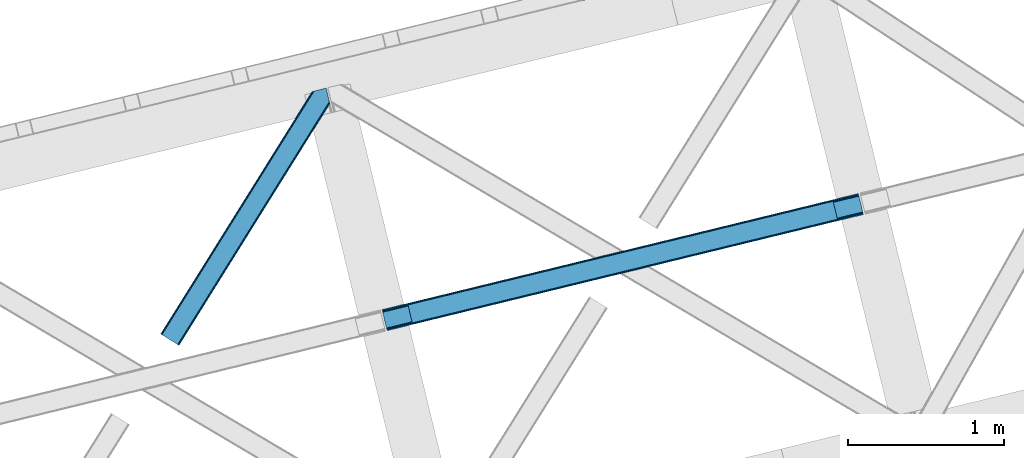
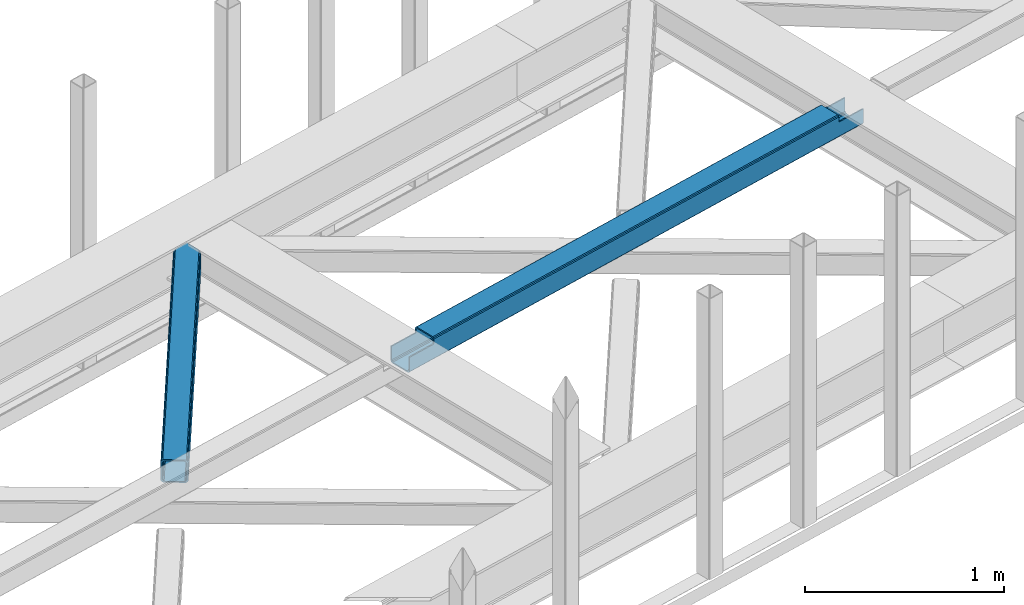
# One storey, part 51 of 67: 1 beam, 1 member.
"""IFC4 building model written with IfcOpenShell, lengths in millimetres."""

from ifc_helpers import new_model, entity, si_unit, converted_unit, derived_unit, direction, frame, origin, place, context, subcontext, project, spatial, triangles, polygons, material, type_object, element, save


model = new_model("IFC4")

# Units and contexts
model_context = context("Model", 3, precision=0.01, world=origin(), true_north=direction((6.12303176911189e-17, 1.0)))
plan_context = context("Plan", 3, precision=0.01, world=origin(), true_north=direction((6.12303176911189e-17, 1.0)))
body_context = subcontext(model_context, "Body", "Model", "MODEL_VIEW")
ifc_project = project(units=[si_unit("LENGTHUNIT", "METRE", prefix="MILLI"), si_unit("AREAUNIT", "SQUARE_METRE"), si_unit("VOLUMEUNIT", "CUBIC_METRE"), converted_unit("PLANEANGLEUNIT", "DEGREE", entity("IfcRatioMeasure", 0.0174532925199433), si_unit("PLANEANGLEUNIT", "RADIAN"), dimensions=[0, 0, 0, 0, 0, 0, 0]), si_unit("MASSUNIT", "GRAM", prefix="KILO"), derived_unit("MASSDENSITYUNIT", [(si_unit("MASSUNIT", "GRAM", prefix="KILO"), 1), (si_unit("LENGTHUNIT", "METRE"), -3)]), derived_unit("MOMENTOFINERTIAUNIT", [(si_unit("LENGTHUNIT", "METRE"), 4)]), si_unit("TIMEUNIT", "SECOND"), si_unit("FREQUENCYUNIT", "HERTZ"), si_unit("THERMODYNAMICTEMPERATUREUNIT", "DEGREE_CELSIUS"), derived_unit("THERMALTRANSMITTANCEUNIT", [(si_unit("MASSUNIT", "GRAM", prefix="KILO"), 1), (si_unit("THERMODYNAMICTEMPERATUREUNIT", "KELVIN"), -1), (si_unit("TIMEUNIT", "SECOND"), -3)]), derived_unit("VOLUMETRICFLOWRATEUNIT", [(si_unit("LENGTHUNIT", "METRE"), 3), (si_unit("TIMEUNIT", "SECOND"), -1)]), derived_unit("MASSFLOWRATEUNIT", [(si_unit("MASSUNIT", "GRAM", prefix="KILO"), 1), (si_unit("TIMEUNIT", "SECOND"), -1)]), derived_unit("ROTATIONALFREQUENCYUNIT", [(si_unit("TIMEUNIT", "SECOND"), -1)]), si_unit("ELECTRICCURRENTUNIT", "AMPERE"), si_unit("ELECTRICVOLTAGEUNIT", "VOLT"), si_unit("POWERUNIT", "WATT"), si_unit("FORCEUNIT", "NEWTON", prefix="KILO"), si_unit("ILLUMINANCEUNIT", "LUX"), si_unit("LUMINOUSFLUXUNIT", "LUMEN"), si_unit("LUMINOUSINTENSITYUNIT", "CANDELA"), derived_unit("USERDEFINED", [(si_unit("MASSUNIT", "GRAM", prefix="KILO"), -1), (si_unit("LENGTHUNIT", "METRE"), -2), (si_unit("TIMEUNIT", "SECOND"), 3), (si_unit("LUMINOUSFLUXUNIT", "LUMEN"), 1)]), derived_unit("LINEARVELOCITYUNIT", [(si_unit("LENGTHUNIT", "METRE"), 1), (si_unit("TIMEUNIT", "SECOND"), -1)]), si_unit("PRESSUREUNIT", "PASCAL"), derived_unit("USERDEFINED", [(si_unit("LENGTHUNIT", "METRE"), -2), (si_unit("MASSUNIT", "GRAM", prefix="KILO"), 1), (si_unit("TIMEUNIT", "SECOND"), -2)]), derived_unit("LINEARFORCEUNIT", [(si_unit("MASSUNIT", "GRAM", prefix="KILO"), 1), (si_unit("LENGTHUNIT", "METRE"), 1), (si_unit("TIMEUNIT", "SECOND"), -2), (si_unit("LENGTHUNIT", "METRE"), -1)]), derived_unit("PLANARFORCEUNIT", [(si_unit("MASSUNIT", "GRAM", prefix="KILO"), 1), (si_unit("LENGTHUNIT", "METRE"), 1), (si_unit("TIMEUNIT", "SECOND"), -2), (si_unit("LENGTHUNIT", "METRE"), -2)])], contexts=[model_context, plan_context])

# Site, building, storey
site_placement = place(None, origin())
site = spatial("IfcSite", under=ifc_project, at=site_placement, CompositionType="ELEMENT")
building_placement = place(site_placement, origin())
building = spatial("IfcBuilding", under=site, at=building_placement, CompositionType="ELEMENT")
storey_placement = place(building_placement, frame((0.0, 0.0, 19800.0)))
storey = spatial("IfcBuildingStorey", under=building, at=storey_placement, CompositionType="ELEMENT", Elevation=19800.0)

# Beam
ifc_material = material(Name="Metal painted (White)")
beam_type = type_object("IfcBeamType", PredefinedType="BEAM")
beam_placement = place(storey_placement, frame((-14457.7709795743, 15615.7078318904, 3967.02022389142)))
element("IfcBeam", 1, at=beam_placement, inside=storey, type_object=beam_type, material=ifc_material, ObjectType="Steel Beam", PredefinedType="BEAM", context=body_context, shape_type="Tessellation", body=[
    polygons([(31.1823923917744, 8.09507685196541, 17.8030399336114), (31.4978703677273, 6.80086440699434, 24.4999999999988), (3089.94374939707, 752.329405140575, 24.4999999999988), (3089.62827142111, 753.623617585539, 17.8030399336114), (30.2839871259186, 11.7806820741907, 12.1256313292298), (3088.72986615526, 757.309222807769, 12.1256313292298), (28.9394286278386, 17.2965800886796, 8.33210818105214), (3087.38530765717, 762.825120822256, 8.33210818105214), (27.3534137404056, 23.8030254244704, 7.00000000000274), (3085.79929276974, 769.331566158046, 7.00000000000274), (4.21622439084776, 118.720708051134, 8.33210818105214), (5.80223927828505, 112.214262715345, 7.00000000000274), (3064.24811830762, 857.742803448923, 7.00000000000274), (3062.66210342018, 864.249248784712, 8.33210818105214), (2.8716658927634, 124.236606065622, 12.1256313292342), (3061.3175449221, 869.765146799201, 12.1256313292342), (1.97326062691193, 127.92221128785, 17.8030399336114), (3060.41913965625, 873.450752021428, 17.8030399336114), (1.65778265094818, 129.216423732819, 24.4999999999988), (3060.10366168029, 874.744964466399, 24.4999999999988), (33.1556530186539, 2.16573425859679e-12, 17.5000000000004), (33.1556530186539, 2.16573425859679e-12, 99.499999999999), (31.4978703677187, 6.80086440699001, 99.499999999999), (1.65778265093735, 129.216423732819, 99.499999999999), (6.49720277579036e-12, 136.017288139807, 99.499999999999), (8.66293703438714e-12, 136.017288139807, 17.5000000000004), (0.315477975968082, 134.72307569484, 10.803039933613), (1.21388324181955, 131.037470472612, 5.12563132923143), (2.55844173990175, 125.521572458124, 1.33210818105373), (4.14445662733688, 119.015127122331, 0.0), (29.0111963913235, 17.0021610174783, 0.0), (30.5972112787608, 10.4957156816875, 1.33210818105373), (31.941769776843, 4.97981766719635, 5.12563132923576), (32.8401750426966, 1.29421244496891, 10.803039933613), (3058.44587902936, 881.545828873391, 17.5000000000004), (3058.44587902936, 881.545828873391, 99.499999999999), (3060.10366168029, 874.744964466399, 99.499999999999), (3089.94374939708, 752.329405140575, 99.499999999999), (3091.60153204801, 745.528540733585, 99.499999999999), (3091.60153204801, 745.528540733585, 17.5000000000004), (3091.28605407205, 746.822753178554, 10.803039933613), (3090.3876488062, 750.508358400777, 5.12563132923576), (3089.04309030811, 756.024256415268, 1.33210818105373), (3087.45707542068, 762.530701751058, 0.0), (3062.59033565669, 864.543667855915, 0.0), (3061.00432076926, 871.050113191704, 1.33210818105373), (3059.65976227117, 876.566011206193, 5.12563132923143), (3058.76135700532, 880.251616428422, 10.803039933613), (2925.75994180944, 712.307865540889, 115.5000123926), (2925.81630989431, 712.321604759507, 100.117303289864), (2926.72300362931, 712.542621518195, 99.499999999999), (194.718606580803, 46.5876811586757, 99.5063429816656), (195.631369831908, 46.810141494503, 100.117301735448), (195.69016819362, 46.8244741223611, 115.5), (2928.38078628024, 705.741757111203, 99.499999999999), (2927.47422618801, 705.520772937698, 100.117303484932), (2927.41464342033, 705.506249905358, 122.500007895425), (197.345360928039, 40.0229783796023, 122.500002534479), (197.33858709673, 40.0213271441479, 100.500009163303), (196.748205195731, 39.8773799905087, 99.5697919021647), (2896.88292546721, 834.958147714718, 99.5063429816656), (2895.97381660776, 834.736577552001, 100.117299778624), (2895.91744852289, 834.722838333385, 115.50000888136), (165.850080476841, 169.240033448186, 115.5), (165.840462203334, 169.237688832044, 100.50000941238), (165.250325295043, 169.093836777335, 99.5761204674868), (2894.85332685229, 841.668448882885, 99.5697919021647), (163.220745767771, 175.804071762186, 99.499999999999), (164.133244938508, 176.026503182397, 100.117301984524), (164.189439987617, 176.040201208966, 122.500002796667), (2894.25631754638, 841.522886341469, 122.500003994045), (2894.26642083521, 841.525349756033, 100.500018741102), (2894.56843170077, 840.227853719305, 129.196959150505), (2895.46176722636, 836.541012377613, 134.874360354937), (2896.80305823042, 831.024317672808, 138.667878733795), (2898.38810531643, 824.517636364731, 139.999985502214), (2923.25885436336, 722.50564781542, 139.999991354279), (2924.84634848094, 715.999563150015, 138.667885332354), (2926.19460804138, 710.484567539786, 134.874367586349), (2927.09837274859, 706.800269072834, 129.196966804773), (2925.44675217775, 713.602635936908, 122.196975799125), (2924.54298747053, 717.286934403865, 127.874376580702), (2923.1947279101, 722.801930014085, 131.667894326702), (2921.60723379251, 729.30801467949, 133.000000348631), (2900.05258461851, 817.718404755563, 132.999995276841), (2898.4675375325, 824.225086063638, 131.667888508414), (2897.12624652844, 829.741780768443, 127.874370129564), (2896.23291100285, 833.428622110137, 122.196968925133), (164.878528418706, 169.003207355194, 99.499999999999), (193.131726453727, 57.3201898040377, 131.667891818946), (191.54571156629, 63.8266351398307, 133.0), (194.476284951809, 51.8042917895531, 127.874368670764), (195.374690217663, 48.1186865673257, 122.196960066391), (169.994537104169, 152.237872430709, 133.0), (166.165558452801, 167.945821003215, 122.196960066391), (167.063963718652, 164.260215780989, 127.874368670764), (168.408522216739, 158.7443177665, 131.667891818946), (197.03141194405, 41.3175635421116, 129.196961104604), (196.136488323042, 45.0040174738981, 134.874366301861), (194.794244157291, 50.5204796458708, 138.667887185257), (193.209023953562, 57.0271186991972, 139.999994588639), (168.341882306922, 159.039986838386, 139.999994981919), (166.755021471167, 165.546225960032, 138.667887628704), (165.408105180711, 171.061549222925, 134.874366787843), (164.506189230946, 174.746298656824, 129.196961619)], [[[1, 2, 3, 4]], [[5, 1, 4, 6]], [[7, 5, 6, 8]], [[9, 7, 8, 10]], [[11, 12, 13, 14]], [[15, 11, 14, 16]], [[17, 15, 16, 18]], [[19, 17, 18, 20]], [[12, 9, 10, 13]], [[21, 22, 23, 2, 1, 5, 7, 9, 12, 11, 15, 17, 19, 24, 25, 26, 27, 28, 29, 30, 31, 32, 33, 34]], [[35, 36, 37, 20, 18, 16, 14, 13, 10, 8, 6, 4, 3, 38, 39, 40, 41, 42, 43, 44, 45, 46, 47, 48]], [[49, 50, 51, 38, 3, 2, 23, 52, 53, 54]], [[55, 39, 38, 51]], [[39, 55, 56, 57, 58, 59, 60, 22, 21, 40]], [[32, 31, 44, 43]], [[33, 32, 43, 42]], [[34, 33, 42, 41]], [[21, 34, 41, 40]], [[31, 30, 45, 44]], [[27, 26, 35, 48]], [[28, 27, 48, 47]], [[29, 28, 47, 46]], [[30, 29, 46, 45]], [[20, 37, 61, 62, 63, 64, 65, 66, 24, 19]], [[67, 36, 35, 26, 25, 68, 69, 70, 71, 72]], [[36, 67, 61, 37]], [[72, 71, 73, 74, 75, 76, 77, 78, 79, 80, 57, 56, 50, 49, 81, 82, 83, 84, 85, 86, 87, 88, 63, 62]], [[60, 52, 23, 22]], [[25, 24, 89, 68]], [[90, 91, 84, 83]], [[92, 90, 83, 82]], [[93, 92, 82, 81]], [[54, 93, 81, 49]], [[94, 85, 84, 91]], [[95, 64, 63, 88]], [[96, 95, 88, 87]], [[97, 96, 87, 86]], [[94, 97, 86, 85]], [[65, 64, 95, 96, 97, 94, 91, 90, 92, 93, 54, 53, 59, 58, 98, 99, 100, 101, 102, 103, 104, 105, 70, 69]], [[98, 58, 57, 80]], [[99, 98, 80, 79]], [[100, 99, 79, 78]], [[101, 100, 78, 77]], [[77, 76, 102, 101]], [[103, 102, 76, 75]], [[104, 103, 75, 74]], [[105, 104, 74, 73]], [[70, 105, 73, 71]]], closed=False),
])

# Member
member_type = type_object("IfcMemberType", PredefinedType="BRACE")
member_placement = place(storey_placement, frame((-15879.7435089111, 15520.9677337647, 3822.99993896484)))
element("IfcMember", 2, at=member_placement, inside=storey, type_object=member_type, ObjectType="Steel Horizontal Brace", PredefinedType="BRACE", context=body_context, shape_type="Tessellation", body=[
    triangles([(933.020956420898, 1535.69230957031, 0.0), (967.780462646484, 1393.09287414551, 0.0), (14.8444427490231, 64.8704589843746, 0.0), (103.914587402343, 9.2680389404286, 0.0), (928.803771972656, 1552.99241638184, 5.49966430664063), (928.943298339844, 1552.41687011719, 5.208984375), (930.803649902344, 1544.78826599121, 1.33247680664135), (971.997647094726, 1375.79393005371, 5.49966430664063), (971.856958007813, 1376.36831359863, 5.208984375), (969.997769165038, 1383.99808044434, 1.33247680664135), (972.208099365234, 1375.53813171387, 5.8531311035149), (972.423202514648, 1375.28349609375, 6.20659790039281), (928.911904907227, 1553.57028808594, 5.74383544921875), (972.725509643555, 1375.53929443359, 6.35310058593677), (929.027014160156, 1554.1772277832, 5.9996337890625), (973.026654052734, 1375.79393005371, 6.49960327148438), (929.142123413085, 1554.78416748047, 6.25543212890625), (929.254907226563, 1555.3632019043, 6.49960327148438), (4.34857177734375, 71.4235473632798, 5.12526855468968), (1.13016357421839, 73.4315643310547, 10.8039916992202), (973.360354614257, 1630.84347839356, 10.8039916992202), (976.915951538085, 1631.71086730957, 6.49960327148438), (9.16455688476526, 68.4167541503903, 1.33247680664135), (971.508142089844, 1630.39234313965, 17.5012573242202), (0.0, 74.1373352050778, 17.5012573242202), (1081.10145263672, 1548.91824645996, 6.49960327148438), (1056.20878601074, 1651.03875732422, 6.49960327148438), (971.508142089844, 1630.39234313965, 122.499499511719), (0.0, 74.1373352050778, 122.499499511719), (973.360354614257, 1630.84347839356, 129.196765136719), (1.13016357421839, 73.4315643310547, 129.196765136719), (978.633288574218, 1632.12944641113, 134.87548828125), (4.34857177734375, 71.4235473632798, 134.87548828125), (986.526992797852, 1634.05374755859, 138.668280029298), (9.16455688476526, 68.4167541503903, 138.668280029298), (995.840377807617, 1636.32337646484, 140.00075683594), (14.8444427490231, 64.8704589843746, 140.00075683594), (118.757867431641, 0.0, 17.5012573242202), (117.628866577148, 0.705770874023074, 10.8039916992202), (1085.14190368652, 1551.25182495117, 10.9783996582046), (1087.41734619141, 1552.56569824219, 13.4991760253906), (109.594473266601, 5.72174377441297, 1.33247680664135), (114.410458374023, 2.71495056152344, 5.12526855468968), (1087.56966247559, 1551.93550415039, 17.5012573242202), (1081.77699279785, 1575.70265808105, 140.00075683594), (1063.00837097168, 1652.6967956543, 140.00075683594), (103.914587402343, 9.2680389404286, 140.00075683594), (1083.99429931641, 1566.60786437988, 138.668280029298), (109.594473266601, 5.72174377441297, 138.668280029298), (1085.87325439453, 1558.89670715332, 134.87548828125), (114.410458374023, 2.71495056152344, 134.87548828125), (1087.12899169922, 1553.74469604492, 129.196765136719), (117.628866577148, 0.705770874023074, 129.196765136719), (1087.56966247559, 1551.93550415039, 122.499499511719), (118.757867431641, 0.0, 122.499499511719), (1082.5362487793, 1566.77413330078, 12.1248413085959), (1083.96523132324, 1566.72529907227, 13.4991760253906), (1077.85165100098, 1569.98672790527, 8.3320495605476), (1074.64603271484, 1577.50138549805, 6.99957275390625), (1056.69131469727, 1651.1561920166, 6.99957275390625), (1005.57350463867, 1638.69648742676, 6.99957275390625), (20.7836151123047, 61.163708496093, 6.99957275390625), (97.9789031982418, 12.9759521484375, 6.99957275390625), (108.475936889648, 6.42286376953052, 12.1248413085959), (111.694345092774, 4.41368408203016, 17.8035644531265), (1084.81169128418, 1563.25225524902, 17.8035644531265), (103.659951782227, 9.42849426269458, 8.3320495605476), (1085.25236206055, 1561.44306335449, 24.5008300781265), (112.823345947265, 3.70791320800708, 24.5008300781265), (983.093481445312, 1633.21658935547, 17.8035644531265), (981.241268920898, 1632.76429138183, 24.5008300781265), (7.0693359375, 69.7248138427731, 17.8035644531265), (5.94033508300708, 70.4305847167961, 24.5008300781265), (988.366415405273, 1634.50139465332, 12.1248413085959), (10.2877441406254, 67.716796875, 12.1248413085959), (996.260119628905, 1636.42569580078, 8.3320495605476), (15.1037292480469, 64.7100036621086, 8.3320495605476), (981.241268920898, 1632.76429138183, 115.499926757813), (5.94033508300708, 70.4305847167961, 115.499926757813), (996.260119628905, 1636.42569580078, 131.668707275392), (1005.57350463867, 1638.69648742676, 133.001184082033), (1063.00837097168, 1652.6967956543, 133.001184082033), (988.366415405273, 1634.50139465332, 127.873590087893), (983.093481445312, 1633.21658935547, 122.197192382813), (20.7836151123047, 61.163708496093, 133.001184082033), (15.1037292480469, 64.7100036621086, 131.668707275392), (10.2877441406254, 67.716796875, 127.873590087893), (7.0693359375, 69.7248138427731, 122.197192382813), (108.475936889648, 6.42286376953052, 127.873590087893), (111.694345092774, 4.41368408203016, 122.197192382813), (112.823345947265, 3.70791320800708, 115.499926757813), (97.9789031982418, 12.9759521484375, 133.001184082033), (103.659951782227, 9.42849426269458, 131.668707275392), (1085.25236206055, 1561.44306335449, 115.499926757813), (1084.81169128418, 1563.25225524902, 122.197192382813), (1083.55595397949, 1568.40426635742, 127.873590087893), (1081.67699890137, 1576.11426086426, 131.668707275392), (1079.45969238281, 1585.20905456543, 133.001184082033)], [[1, 2, 3], [4, 3, 2], [1, 5, 2], [6, 5, 1], [1, 7, 6], [2, 5, 8], [8, 9, 2], [10, 2, 9], [11, 8, 5], [12, 11, 13], [14, 12, 15], [16, 14, 17], [17, 18, 16], [15, 17, 14], [13, 15, 12], [5, 13, 11], [17, 19, 18], [19, 17, 15], [13, 19, 15], [19, 13, 5], [5, 6, 19], [20, 21, 18], [18, 19, 20], [21, 22, 18], [19, 6, 7], [7, 1, 23], [3, 23, 1], [7, 23, 19], [24, 21, 20], [20, 25, 24], [18, 26, 16], [26, 18, 22], [27, 26, 22], [28, 24, 25], [25, 29, 28], [30, 28, 31], [29, 31, 28], [32, 30, 33], [31, 33, 30], [34, 32, 35], [33, 35, 32], [36, 34, 37], [35, 37, 34], [38, 39, 40], [40, 41, 38], [42, 10, 9], [39, 12, 16], [16, 40, 39], [16, 26, 40], [9, 39, 43], [9, 12, 39], [9, 43, 42], [2, 10, 4], [42, 4, 10], [41, 44, 38], [45, 36, 37], [36, 45, 46], [37, 47, 45], [48, 45, 47], [47, 49, 48], [50, 48, 49], [49, 51, 50], [52, 50, 51], [51, 53, 52], [54, 52, 53], [53, 55, 54], [44, 54, 38], [55, 38, 54], [56, 40, 26], [41, 40, 56], [56, 57, 41], [58, 26, 59], [26, 58, 56], [60, 59, 26], [59, 61, 62], [61, 59, 60], [62, 63, 59], [64, 65, 66], [66, 57, 64], [58, 59, 63], [63, 67, 58], [56, 58, 67], [67, 64, 56], [57, 56, 64], [68, 66, 65], [65, 69, 68], [70, 71, 72], [73, 72, 71], [74, 70, 75], [72, 75, 70], [76, 74, 77], [75, 77, 74], [61, 76, 62], [77, 62, 76], [71, 78, 79], [79, 73, 71], [34, 36, 80], [46, 81, 36], [81, 46, 82], [81, 80, 36], [83, 34, 80], [83, 32, 34], [32, 84, 30], [84, 32, 83], [28, 84, 78], [84, 28, 30], [61, 22, 76], [70, 74, 22], [74, 76, 22], [61, 60, 22], [71, 70, 24], [21, 24, 70], [28, 71, 24], [71, 28, 78], [70, 22, 21], [80, 81, 85], [85, 86, 80], [83, 80, 86], [86, 87, 83], [84, 83, 87], [87, 88, 84], [78, 84, 88], [88, 79, 78], [53, 89, 90], [91, 38, 55], [53, 90, 55], [53, 51, 89], [90, 91, 55], [89, 51, 49], [92, 47, 37], [47, 93, 49], [93, 47, 92], [93, 89, 49], [39, 64, 43], [69, 38, 91], [38, 65, 39], [65, 38, 69], [39, 65, 64], [4, 63, 3], [42, 43, 64], [64, 67, 42], [67, 63, 4], [4, 42, 67], [87, 35, 33], [37, 85, 92], [37, 86, 85], [86, 37, 35], [87, 86, 35], [79, 29, 25], [31, 88, 87], [33, 31, 87], [88, 31, 29], [79, 88, 29], [23, 75, 19], [3, 63, 62], [62, 77, 3], [77, 75, 23], [23, 3, 77], [20, 19, 75], [25, 73, 79], [72, 25, 20], [25, 72, 73], [72, 20, 75], [66, 41, 57], [54, 44, 68], [44, 66, 68], [68, 94, 54], [44, 41, 66], [95, 54, 94], [52, 54, 95], [50, 95, 96], [95, 50, 52], [96, 48, 50], [97, 48, 96], [97, 98, 45], [97, 45, 48], [98, 46, 45], [98, 82, 46], [81, 98, 85], [81, 82, 98], [92, 85, 98], [95, 94, 90], [91, 90, 94], [96, 95, 89], [90, 89, 95], [97, 96, 93], [89, 93, 96], [98, 97, 92], [93, 92, 97], [94, 68, 69], [69, 91, 94]]),
])

save(model, "model.ifc")
